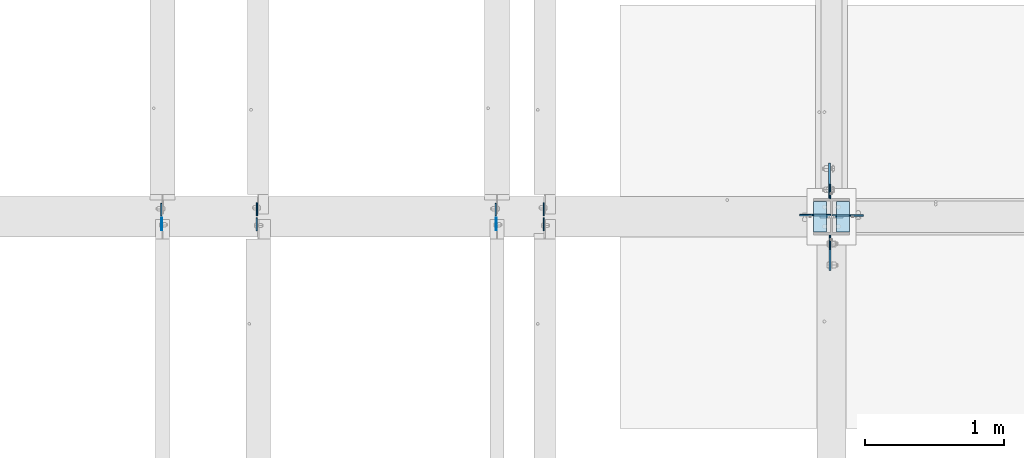
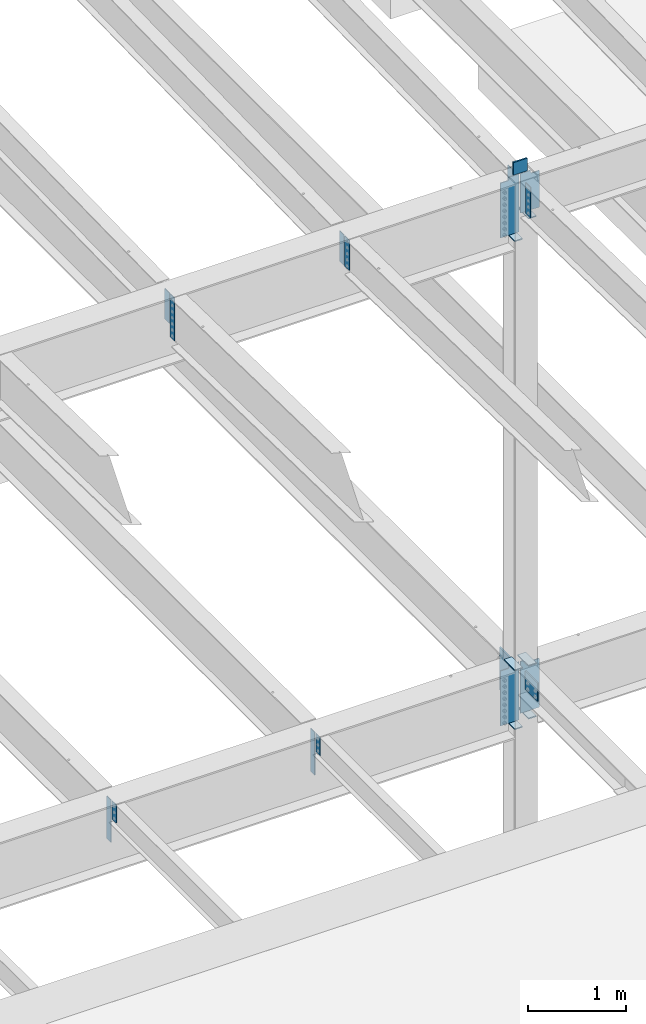
# One storey, part 1558 of 1763: 23 plates, 4 elements without a shape of their own.
"""IFC2X3 building model written with IfcOpenShell, lengths in millimetres."""

from ifc_helpers import new_model, si_unit, frame, origin_with_axes, place, context, subcontext, project, spatial, faceted_brep, material, type_object, element, aggregate, save


model = new_model("IFC2X3")

# Units and contexts
model_context = context("Model", 3, precision=1e-05, world=origin_with_axes())
body_context = subcontext(model_context, "Body", "Model", "MODEL_VIEW")
ifc_project = project(units=[si_unit("LENGTHUNIT", "METRE", prefix="MILLI"), si_unit("AREAUNIT", "SQUARE_METRE"), si_unit("VOLUMEUNIT", "CUBIC_METRE"), si_unit("MASSUNIT", "GRAM", prefix="KILO"), si_unit("TIMEUNIT", "SECOND"), si_unit("PLANEANGLEUNIT", "RADIAN"), si_unit("SOLIDANGLEUNIT", "STERADIAN"), si_unit("THERMODYNAMICTEMPERATUREUNIT", "DEGREE_CELSIUS"), si_unit("LUMINOUSINTENSITYUNIT", "LUMEN")], contexts=[model_context])

# Site, building, storey
site_placement = place(None, origin_with_axes())
site = spatial("IfcSite", under=ifc_project, at=site_placement, CompositionType="ELEMENT")
building_placement = place(site_placement, origin_with_axes())
building = spatial("IfcBuilding", under=site, at=building_placement, Name="Undefined", CompositionType="ELEMENT")
storey_placement = place(building_placement, origin_with_axes())
storey = spatial("IfcBuildingStorey", under=building, at=storey_placement, Name="Undefined", CompositionType="ELEMENT", Elevation=0.0)

# Assembly, plates
assembly_1_placement = place(storey_placement, origin_with_axes())
assembly_1 = element("IfcElementAssembly", 1, at=assembly_1_placement, inside=storey, Name="COLUMN", AssemblyPlace="NOTDEFINED", PredefinedType="RIGID_FRAME")
ifc_material_1 = material(Name="STEEL/A36")
plate_type_1 = type_object("IfcPlateType", PredefinedType="NOTDEFINED")
plate_1_placement = place(assembly_1_placement, frame((-34957.7750236983, 29891.0375000001, 11256.2657630561), z_axis=(0.0, -1.0, 0.0), x_axis=(0.0, 0.0, -1.0)))
plate_1 = element("IfcPlate", 2, at=plate_1_placement, type_object=plate_type_1, material=ifc_material_1, Name="PLATE", context=body_context, shape_type="Brep", body=[
    faceted_brep([(0.0, -3.96900000000096, 0.0), (-1.18234311230481e-11, -3.96900000000096, 101.599998474121), (-1.18234311230481e-11, 3.96900000000096, 101.599998474121), (0.0, 3.96900000000096, 0.0), (381.0, -3.96899999999732, 101.599998474121), (381.0, 3.96899999999732, 101.599998474121), (381.0, -3.96900000001915, 3.34694050252438e-10), (381.0, 3.9690000000046, 3.20142135024071e-10)], [[[0, 1, 2, 3]], [[1, 4, 5, 2]], [[4, 6, 7, 5]], [[6, 0, 3, 7]], [[5, 7, 3, 2]], [[6, 4, 1, 0]]]),
])
plate_2_placement = place(assembly_1_placement, frame((-34957.7750236983, 30154.5624999999, 11256.2236063032), z_axis=(0.0, 1.0, 0.0), x_axis=(0.0, 0.0, -1.0)))
plate_2 = element("IfcPlate", 3, at=plate_2_placement, type_object=plate_type_1, material=ifc_material_1, Name="PLATE", context=body_context, shape_type="Brep", body=[
    faceted_brep([(0.0, -3.96900000000096, 0.0), (-1.18234311230481e-11, -3.96900000000096, 101.599998474121), (-1.18234311230481e-11, 3.96900000000096, 101.599998474121), (0.0, 3.96900000000096, 0.0), (381.0, -3.96899999999732, 101.599998474121), (381.0, 3.96899999999732, 101.599998474121), (381.0, -3.96900000001915, 3.34694050252438e-10), (381.0, 3.9690000000046, 3.20142135024071e-10)], [[[0, 1, 2, 3]], [[1, 4, 5, 2]], [[4, 6, 7, 5]], [[6, 0, 3, 7]], [[5, 7, 3, 2]], [[6, 4, 1, 0]]]),
])

assembly_2_placement = place(storey_placement, origin_with_axes())
assembly_2 = element("IfcElementAssembly", 4, at=assembly_2_placement, inside=storey, Name="BEAM", AssemblyPlace="NOTDEFINED", PredefinedType="RIGID_FRAME")
plate_type_2 = type_object("IfcPlateType", PredefinedType="NOTDEFINED")
plate_3_placement = place(assembly_2_placement, frame((-39776.8956070317, 30029.94375, 5143.5), z_axis=(0.0, 1.0, 0.0), x_axis=(0.0, 0.0, -1.0)))
plate_3 = element("IfcPlate", 5, at=plate_3_placement, type_object=plate_type_2, material=ifc_material_1, Name="PLATE", context=body_context, shape_type="Brep", body=[
    faceted_brep([(0.0, -4.76249999999982, 0.0), (0.0, -4.76250000000073, 88.9000015258789), (0.0, 4.76250000000073, 88.9000015258789), (0.0, 4.76249999999982, 0.0), (533.400024414062, -4.76250000000073, 88.9000015258789), (533.400024414062, 4.76250000000073, 88.9000015258789), (533.400024414062, -4.76250000000073, 0.0), (533.400024414062, 4.76250000000073, 0.0)], [[[0, 1, 2, 3]], [[1, 4, 5, 2]], [[4, 6, 7, 5]], [[6, 0, 3, 7]], [[5, 7, 3, 2]], [[6, 4, 1, 0]]]),
])
plate_4_placement = place(assembly_2_placement, frame((-37368.128940365, 30029.94375, 5143.5), z_axis=(0.0, 1.0, 0.0), x_axis=(0.0, 0.0, -1.0)))
plate_4 = element("IfcPlate", 6, at=plate_4_placement, type_object=plate_type_2, material=ifc_material_1, Name="PLATE", context=body_context, shape_type="Brep", body=[
    faceted_brep([(0.0, -4.76249999999982, 0.0), (0.0, -4.76250000000073, 88.9000015258789), (0.0, 4.76250000000073, 88.9000015258789), (0.0, 4.76249999999982, 0.0), (533.400024414062, -4.76250000000073, 88.9000015258789), (533.400024414062, 4.76250000000073, 88.9000015258789), (533.400024414062, -4.76250000000073, 0.0), (533.400024414062, 4.76250000000073, 0.0)], [[[0, 1, 2, 3]], [[1, 4, 5, 2]], [[4, 6, 7, 5]], [[6, 0, 3, 7]], [[5, 7, 3, 2]], [[6, 4, 1, 0]]]),
])
plate_type_3 = type_object("IfcPlateType", PredefinedType="NOTDEFINED")
plate_5_placement = place(assembly_2_placement, frame((-37364.953940365, 30015.65625, 5143.5), z_axis=(0.0, -1.0, 0.0), x_axis=(0.0, 0.0, -1.0)))
plate_5 = element("IfcPlate", 7, at=plate_5_placement, type_object=plate_type_3, material=ifc_material_1, Name="PLATE", context=body_context, shape_type="Brep", body=[
    faceted_brep([(1.81898940354586e-12, -3.17500000000291, 0.0), (0.0, -3.17499999999927, 88.9000015258789), (0.0, 3.17499999999927, 88.9000015258789), (-1.81898940354586e-12, 3.17499999997381, 0.0), (228.600006103516, -3.17499999999927, 88.9000015258789), (228.600006103516, 3.17499999999927, 88.9000015258789), (228.600006103516, -3.17500000001019, -7.27595761418343e-12), (228.600006103516, 3.17499999999563, -7.27595761418343e-12)], [[[0, 1, 2, 3]], [[1, 4, 5, 2]], [[4, 6, 7, 5]], [[6, 0, 3, 7]], [[5, 7, 3, 2]], [[6, 4, 1, 0]]]),
])
plate_6_placement = place(assembly_2_placement, frame((-39773.7206070317, 30015.65625, 5143.5), z_axis=(0.0, -1.0, 0.0), x_axis=(0.0, 0.0, -1.0)))
plate_6 = element("IfcPlate", 8, at=plate_6_placement, type_object=plate_type_3, material=ifc_material_1, Name="PLATE", context=body_context, shape_type="Brep", body=[
    faceted_brep([(1.81898940354586e-12, -3.17500000000291, 0.0), (0.0, -3.17499999999927, 88.9000015258789), (0.0, 3.17499999999927, 88.9000015258789), (-1.81898940354586e-12, 3.17499999997381, 0.0), (228.600006103516, -3.17499999999927, 88.9000015258789), (228.600006103516, 3.17499999999927, 88.9000015258789), (228.600006103516, -3.17500000001019, -7.27595761418343e-12), (228.600006103516, 3.17499999999563, -7.27595761418343e-12)], [[[0, 1, 2, 3]], [[1, 4, 5, 2]], [[4, 6, 7, 5]], [[6, 0, 3, 7]], [[5, 7, 3, 2]], [[6, 4, 1, 0]]]),
])
aggregate(assembly_2, [plate_3, plate_4, plate_5, plate_6])

# Plate
ifc_material_2 = material(Name="STEEL/A572-50")
plate_type_4 = type_object("IfcPlateType", PredefinedType="NOTDEFINED")
plate_7_placement = place(assembly_1_placement, frame((-34867.2872721725, 30022.8000001452, 11455.3999938869), z_axis=(0.0, 0.0, -1.0), x_axis=(-1.0, 0.0, 0.0)))
plate_7 = element("IfcPlate", 9, at=plate_7_placement, type_object=plate_type_4, material=ifc_material_2, Name="PLATE", context=body_context, shape_type="Brep", body=[
    faceted_brep([(7.27595761418343e-12, 9.52500000000146, 155.574990844727), (-1.45519152283669e-11, 7.27595761418343e-12, 165.099990844727), (165.099990844727, 0.0, 165.099990844727), (165.099990844727, 9.52500000000146, 155.574990844727), (-3.63797880709171e-11, -9.5249999999869, 155.574990844727), (165.099990844727, -9.52500000000146, 155.574990844727), (0.0, 9.52500000000146, 0.0), (0.0, -9.52500000000146, 0.0), (165.099990844727, -9.52500000000146, 0.0), (165.099990844727, 9.52500000000146, 0.0)], [[[0, 1, 2, 3]], [[1, 4, 5, 2]], [[6, 7, 4, 1, 0]], [[5, 8, 9, 3, 2]], [[8, 7, 6, 9]], [[9, 6, 0, 3]], [[7, 8, 5, 4]]]),
])

plate_type_5 = type_object("IfcPlateType", PredefinedType="NOTDEFINED")
plate_8_placement = place(assembly_1_placement, frame((-34821.2497736983, 29911.675, 10775.9500122022), z_axis=(0.0, 1.0, 0.0), x_axis=(-1.0, 0.0, 0.0)))
plate_8 = element("IfcPlate", 10, at=plate_8_placement, type_object=plate_type_5, material=ifc_material_1, Name="PLATE", context=body_context, shape_type="Brep", body=[
    faceted_brep([(0.0, -6.34999999999491, 1.45519152283669e-11), (0.0, -6.35000000000036, 222.25), (0.0, 6.35000000000036, 222.25), (0.0, 6.34999999999491, -2.91038304567337e-11), (93.6624984741211, -6.35000000000036, 222.25), (93.6624984741211, 6.35000000000036, 222.25), (93.6624984741211, -6.35000000000036, 0.0), (93.6624984741211, 6.35000000000036, 0.0)], [[[0, 1, 2, 3]], [[1, 4, 5, 2]], [[4, 6, 7, 5]], [[6, 0, 3, 7]], [[5, 7, 3, 2]], [[6, 4, 1, 0]]]),
])

plate_9_placement = place(assembly_1_placement, frame((-35078.4247736984, 30133.925, 10547.2838431128), z_axis=(0.0, -1.0, 0.0), x_axis=(1.0, 0.0, 0.0)))
plate_9 = element("IfcPlate", 11, at=plate_9_placement, type_object=plate_type_5, material=ifc_material_1, Name="PLATE", context=body_context, shape_type="Brep", body=[
    faceted_brep([(0.0, -6.34999999999491, 1.45519152283669e-11), (0.0, -6.35000000000036, 222.25), (0.0, 6.35000000000036, 222.25), (0.0, 6.34999999999491, -2.91038304567337e-11), (93.6624984741211, -6.35000000000036, 222.25), (93.6624984741211, 6.35000000000036, 222.25), (93.6624984741211, -6.35000000000036, 0.0), (93.6624984741211, 6.35000000000036, 0.0)], [[[0, 1, 2, 3]], [[1, 4, 5, 2]], [[4, 6, 7, 5]], [[6, 0, 3, 7]], [[5, 7, 3, 2]], [[6, 4, 1, 0]]]),
])

plate_10_placement = place(assembly_1_placement, frame((-35078.4247736984, 30133.925, 4451.34997558594), z_axis=(0.0, -1.0, 0.0), x_axis=(1.0, 0.0, 0.0)))
plate_10 = element("IfcPlate", 12, at=plate_10_placement, type_object=plate_type_5, material=ifc_material_1, Name="PLATE", context=body_context, shape_type="Brep", body=[
    faceted_brep([(0.0, -6.34999999999491, 1.45519152283669e-11), (0.0, -6.35000000000036, 222.25), (0.0, 6.35000000000036, 222.25), (0.0, 6.34999999999491, -2.91038304567337e-11), (93.6624984741211, -6.35000000000036, 222.25), (93.6624984741211, 6.35000000000036, 222.25), (93.6624984741211, -6.35000000000036, 0.0), (93.6624984741211, 6.35000000000036, 0.0)], [[[0, 1, 2, 3]], [[1, 4, 5, 2]], [[4, 6, 7, 5]], [[6, 0, 3, 7]], [[5, 7, 3, 2]], [[6, 4, 1, 0]]]),
])

plate_11_placement = place(assembly_1_placement, frame((-35078.4247736984, 30133.925, 5187.95), z_axis=(0.0, -1.0, 0.0), x_axis=(1.0, 0.0, 0.0)))
plate_11 = element("IfcPlate", 13, at=plate_11_placement, type_object=plate_type_5, material=ifc_material_1, Name="PLATE", context=body_context, shape_type="Brep", body=[
    faceted_brep([(0.0, -6.34999999999491, 1.45519152283669e-11), (0.0, -6.35000000000036, 222.25), (0.0, 6.35000000000036, 222.25), (0.0, 6.34999999999491, -2.91038304567337e-11), (93.6624984741211, -6.35000000000036, 222.25), (93.6624984741211, 6.35000000000036, 222.25), (93.6624984741211, -6.35000000000036, 0.0), (93.6624984741211, 6.35000000000036, 0.0)], [[[0, 1, 2, 3]], [[1, 4, 5, 2]], [[4, 6, 7, 5]], [[6, 0, 3, 7]], [[5, 7, 3, 2]], [[6, 4, 1, 0]]]),
])

plate_12_placement = place(assembly_1_placement, frame((-34821.2497736983, 29911.675, 4527.54998779297), z_axis=(0.0, 1.0, 0.0), x_axis=(-1.0, 0.0, 0.0)))
plate_12 = element("IfcPlate", 14, at=plate_12_placement, type_object=plate_type_5, material=ifc_material_1, Name="PLATE", context=body_context, shape_type="Brep", body=[
    faceted_brep([(0.0, -6.34999999999491, 1.45519152283669e-11), (0.0, -6.35000000000036, 222.25), (0.0, 6.35000000000036, 222.25), (0.0, 6.34999999999491, -2.91038304567337e-11), (93.6624984741211, -6.35000000000036, 222.25), (93.6624984741211, 6.35000000000036, 222.25), (93.6624984741211, -6.35000000000036, 0.0), (93.6624984741211, 6.35000000000036, 0.0)], [[[0, 1, 2, 3]], [[1, 4, 5, 2]], [[4, 6, 7, 5]], [[6, 0, 3, 7]], [[5, 7, 3, 2]], [[6, 4, 1, 0]]]),
])

plate_13_placement = place(assembly_1_placement, frame((-34821.2497736983, 29911.675, 5187.95), z_axis=(0.0, 1.0, 0.0), x_axis=(-1.0, 0.0, 0.0)))
plate_13 = element("IfcPlate", 15, at=plate_13_placement, type_object=plate_type_5, material=ifc_material_1, Name="PLATE", context=body_context, shape_type="Brep", body=[
    faceted_brep([(0.0, -6.34999999999491, 1.45519152283669e-11), (0.0, -6.35000000000036, 222.25), (0.0, 6.35000000000036, 222.25), (0.0, 6.34999999999491, -2.91038304567337e-11), (93.6624984741211, -6.35000000000036, 222.25), (93.6624984741211, 6.35000000000036, 222.25), (93.6624984741211, -6.35000000000036, 0.0), (93.6624984741211, 6.35000000000036, 0.0)], [[[0, 1, 2, 3]], [[1, 4, 5, 2]], [[4, 6, 7, 5]], [[6, 0, 3, 7]], [[5, 7, 3, 2]], [[6, 4, 1, 0]]]),
])

# Assembly, plates
assembly_3_placement = place(storey_placement, origin_with_axes())
assembly_3 = element("IfcElementAssembly", 16, at=assembly_3_placement, inside=storey, Name="BEAM", AssemblyPlace="NOTDEFINED", PredefinedType="RIGID_FRAME")
plate_type_6 = type_object("IfcPlateType", PredefinedType="NOTDEFINED")
plate_14_placement = place(assembly_3_placement, frame((-37022.4321665555, 30029.9437498557, 11239.2233504332), z_axis=(0.0, 1.0, 0.0), x_axis=(0.0, 0.0, -1.0)))
plate_14 = element("IfcPlate", 17, at=plate_14_placement, type_object=plate_type_6, material=ifc_material_1, Name="PLATE", context=body_context, shape_type="Brep", body=[
    faceted_brep([(0.0, -3.96900000000096, 0.0), (0.0, -3.96900000000096, 95.25), (0.0, 3.96900000000096, 95.25), (0.0, 3.96900000000096, 0.0), (381.0, -3.96899999999732, 95.25), (381.0, 3.96899999999732, 95.25), (381.0, -3.96900000001915, 3.34694050252438e-10), (381.0, 3.9690000000046, 3.20142135024071e-10)], [[[0, 1, 2, 3]], [[1, 4, 5, 2]], [[4, 6, 7, 5]], [[6, 0, 3, 7]], [[5, 7, 3, 2]], [[6, 4, 1, 0]]]),
])
plate_15_placement = place(assembly_3_placement, frame((-39087.0893094127, 30029.9437498557, 11239.223350434), z_axis=(0.0, 1.0, 0.0), x_axis=(0.0, 0.0, -1.0)))
plate_15 = element("IfcPlate", 18, at=plate_15_placement, type_object=plate_type_6, material=ifc_material_1, Name="PLATE", context=body_context, shape_type="Brep", body=[
    faceted_brep([(0.0, -3.96900000000096, 0.0), (0.0, -3.96900000000096, 95.25), (0.0, 3.96900000000096, 95.25), (0.0, 3.96900000000096, 0.0), (381.0, -3.96899999999732, 95.25), (381.0, 3.96899999999732, 95.25), (381.0, -3.96900000001915, 3.34694050252438e-10), (381.0, 3.9690000000046, 3.20142135024071e-10)], [[[0, 1, 2, 3]], [[1, 4, 5, 2]], [[4, 6, 7, 5]], [[6, 0, 3, 7]], [[5, 7, 3, 2]], [[6, 4, 1, 0]]]),
])

# Plate
plate_type_7 = type_object("IfcPlateType", PredefinedType="NOTDEFINED")
plate_16_placement = place(assembly_1_placement, frame((-34960.9497736983, 29891.0375, 5156.2), z_axis=(0.0, -1.0, 0.0), x_axis=(0.0, 0.0, -1.0)))
plate_16 = element("IfcPlate", 19, at=plate_16_placement, type_object=plate_type_7, material=ifc_material_2, Name="PLATE", context=body_context, shape_type="Brep", body=[
    faceted_brep([(0.0, -6.34999999999491, 1.45519152283669e-11), (0.0, -6.34999999999854, 254.0), (0.0, 6.34999999999854, 254.0), (0.0, 6.34999999999491, -2.91038304567337e-11), (228.600006103516, -6.34999999999854, 254.0), (228.600006103516, 6.34999999999854, 254.0), (228.600006103565, -6.34999999936554, -7.49423634260893e-10), (228.600006103557, 6.35000000064611, -7.13043846189976e-10)], [[[0, 1, 2, 3]], [[1, 4, 5, 2]], [[4, 6, 7, 5]], [[6, 0, 3, 7]], [[5, 7, 3, 2]], [[6, 4, 1, 0]]]),
])

plate_type_8 = type_object("IfcPlateType", PredefinedType="NOTDEFINED")
plate_17_placement = place(assembly_1_placement, frame((-34964.1247736983, 30154.5625, 5143.5), z_axis=(0.0, 1.0, 0.0), x_axis=(0.0, 0.0, -1.0)))
plate_17 = element("IfcPlate", 20, at=plate_17_placement, type_object=plate_type_8, material=ifc_material_2, Name="PLATE", context=body_context, shape_type="Brep", body=[
    faceted_brep([(-7.27595761418343e-12, -7.9375, 0.0), (0.0, -7.9375, 254.0), (0.0, 7.9375, 254.0), (-7.27595761418343e-12, 7.9375, 0.0), (533.400024414062, -7.9375, 254.0), (533.400024414062, 7.9375, 254.0), (533.400024414062, -7.9375, 0.0), (533.400024414062, 7.9375, 0.0)], [[[0, 1, 2, 3]], [[1, 4, 5, 2]], [[4, 6, 7, 5]], [[6, 0, 3, 7]], [[5, 7, 3, 2]], [[6, 4, 1, 0]]]),
])

plate_type_9 = type_object("IfcPlateType", PredefinedType="NOTDEFINED")
plate_18_placement = place(assembly_1_placement, frame((-34943.4872736984, 30033.1187501452, 11277.5999999952), z_axis=(1.0, 0.0, 0.0), x_axis=(0.0, 0.0, -1.0)))
plate_18 = element("IfcPlate", 21, at=plate_18_placement, type_object=plate_type_9, material=ifc_material_1, Name="PLATE", context=body_context, shape_type="Brep", body=[
    faceted_brep([(25.4000001907334, -4.76250000000073, 122.237503051758), (25.4000001907334, 4.76250000000073, 122.237503051758), (-2.5465851649642e-11, 4.76250000019581, 122.237500000236), (-3.45607986673713e-11, -4.76249999983202, 122.23750000025), (30.2600797087798, -4.76250000000073, 123.204232974349), (30.2600797087798, 4.76250000000073, 123.204232974349), (34.3802561769335, -4.76250000000073, 125.957246874823), (34.3802561769335, 4.76250000000073, 125.957246874823), (37.133270077411, -4.76250000000073, 130.077423342977), (37.133270077411, 4.76250000000073, 130.077423342977), (38.0999999999985, -4.76250000000073, 134.937502861023), (38.0999999999985, 4.76250000000073, 134.937502861023), (38.0999999999985, -4.76250000000073, 223.837493896484), (38.0999999999985, 4.76250000000073, 223.837493896484), (495.299987792969, -4.76250000000073, 0.0), (0.0, -4.76249999999982, 0.0), (0.0, 4.76249999999982, 0.0), (495.299987792969, 4.76250000000073, 0.0), (495.299987792969, -4.76250000000073, 223.837493896484), (495.299987792969, 4.76250000000073, 223.837493896484)], [[[0, 1, 2, 3]], [[4, 5, 1, 0]], [[6, 7, 5, 4]], [[8, 9, 7, 6]], [[10, 11, 9, 8]], [[12, 13, 11, 10]], [[14, 15, 16, 17]], [[18, 14, 17, 19]], [[8, 6, 4, 0, 3, 15, 14, 18, 12, 10]], [[16, 15, 3, 2]], [[19, 17, 16, 2, 1, 5, 7, 9, 11, 13]], [[18, 19, 13, 12]]]),
])

plate_19_placement = place(assembly_1_placement, frame((-34956.1872736983, 30034.7062498557, 11277.5338675269), z_axis=(-1.0, 0.0, 0.0), x_axis=(0.0, 0.0, -1.0)))
plate_19 = element("IfcPlate", 22, at=plate_19_placement, type_object=plate_type_9, material=ifc_material_1, Name="PLATE", context=body_context, shape_type="Brep", body=[
    faceted_brep([(25.4000001907334, -4.76250000000073, 122.237503051758), (25.4000001907334, 4.76250000000073, 122.237503051758), (-2.5465851649642e-11, 4.76250000019581, 122.237500000236), (-3.45607986673713e-11, -4.76249999983202, 122.23750000025), (30.2600797087798, -4.76250000000073, 123.204232974349), (30.2600797087798, 4.76250000000073, 123.204232974349), (34.3802561769335, -4.76250000000073, 125.957246874823), (34.3802561769335, 4.76250000000073, 125.957246874823), (37.133270077411, -4.76250000000073, 130.077423342977), (37.133270077411, 4.76250000000073, 130.077423342977), (38.0999999999985, -4.76250000000073, 134.937502861023), (38.0999999999985, 4.76250000000073, 134.937502861023), (38.0999999999985, -4.76250000000073, 223.837493896484), (38.0999999999985, 4.76250000000073, 223.837493896484), (723.900024414062, -4.76250000000073, 0.0), (0.0, -4.76249999999982, 0.0), (0.0, 4.76249999999982, 0.0), (723.900024414062, 4.76250000000073, 0.0), (723.900024414062, -4.76250000000073, 223.837493896484), (723.900024414062, 4.76250000000073, 223.837493896484)], [[[0, 1, 2, 3]], [[4, 5, 1, 0]], [[6, 7, 5, 4]], [[8, 9, 7, 6]], [[10, 11, 9, 8]], [[12, 13, 11, 10]], [[14, 15, 16, 17]], [[18, 14, 17, 19]], [[8, 6, 4, 0, 3, 15, 14, 18, 12, 10]], [[16, 15, 3, 2]], [[19, 17, 16, 2, 1, 5, 7, 9, 11, 13]], [[18, 19, 13, 12]]]),
])

plate_20_placement = place(assembly_1_placement, frame((-34956.1872736983, 30034.70625, 5181.6), z_axis=(-1.0, 0.0, 0.0), x_axis=(0.0, 0.0, -1.0)))
plate_20 = element("IfcPlate", 23, at=plate_20_placement, type_object=plate_type_9, material=ifc_material_1, Name="PLATE", context=body_context, shape_type="Brep", body=[
    faceted_brep([(25.4000001907334, -4.76250000000073, 122.237503051758), (25.4000001907334, 4.76250000000073, 122.237503051758), (-2.5465851649642e-11, 4.76250000019581, 122.237500000236), (-3.45607986673713e-11, -4.76249999983202, 122.23750000025), (30.2600797087798, -4.76250000000073, 123.204232974349), (30.2600797087798, 4.76250000000073, 123.204232974349), (34.3802561769335, -4.76250000000073, 125.957246874823), (34.3802561769335, 4.76250000000073, 125.957246874823), (37.133270077411, -4.76250000000073, 130.077423342977), (37.133270077411, 4.76250000000073, 130.077423342977), (38.0999999999985, -4.76250000000073, 134.937502861023), (38.0999999999985, 4.76250000000073, 134.937502861023), (38.0999999999985, -4.76250000000073, 223.837493896484), (38.0999999999985, 4.76250000000073, 223.837493896484), (723.900024414062, -4.76250000000073, 0.0), (0.0, -4.76249999999982, 0.0), (0.0, 4.76249999999982, 0.0), (723.900024414062, 4.76250000000073, 0.0), (723.900024414062, -4.76250000000073, 223.837493896484), (723.900024414062, 4.76250000000073, 223.837493896484)], [[[0, 1, 2, 3]], [[4, 5, 1, 0]], [[6, 7, 5, 4]], [[8, 9, 7, 6]], [[10, 11, 9, 8]], [[12, 13, 11, 10]], [[14, 15, 16, 17]], [[18, 14, 17, 19]], [[8, 6, 4, 0, 3, 15, 14, 18, 12, 10]], [[16, 15, 3, 2]], [[19, 17, 16, 2, 1, 5, 7, 9, 11, 13]], [[18, 19, 13, 12]]]),
])

plate_21_placement = place(assembly_1_placement, frame((-34943.4872736984, 30033.9125, 5181.6), z_axis=(1.0, 0.0, 0.0), x_axis=(0.0, 0.0, -1.0)))
plate_21 = element("IfcPlate", 24, at=plate_21_placement, type_object=plate_type_9, material=ifc_material_1, Name="PLATE", context=body_context, shape_type="Brep", body=[
    faceted_brep([(25.4000001907334, -4.76250000000073, 122.237503051758), (25.4000001907334, 4.76250000000073, 122.237503051758), (-2.5465851649642e-11, 4.76250000019581, 122.237500000236), (-3.45607986673713e-11, -4.76249999983202, 122.23750000025), (30.2600797087798, -4.76250000000073, 123.204232974349), (30.2600797087798, 4.76250000000073, 123.204232974349), (34.3802561769335, -4.76250000000073, 125.957246874823), (34.3802561769335, 4.76250000000073, 125.957246874823), (37.133270077411, -4.76250000000073, 130.077423342977), (37.133270077411, 4.76250000000073, 130.077423342977), (38.0999999999985, -4.76250000000073, 134.937502861023), (38.0999999999985, 4.76250000000073, 134.937502861023), (38.0999999999985, -4.76250000000073, 223.837493896484), (38.0999999999985, 4.76250000000073, 223.837493896484), (647.700012207031, -4.76250000000073, 0.0), (0.0, -4.76249999999982, 0.0), (0.0, 4.76249999999982, 0.0), (647.700012207031, 4.76250000000073, 0.0), (647.700012207031, -4.76250000000073, 223.837493896484), (647.700012207031, 4.76250000000073, 223.837493896484)], [[[0, 1, 2, 3]], [[4, 5, 1, 0]], [[6, 7, 5, 4]], [[8, 9, 7, 6]], [[10, 11, 9, 8]], [[12, 13, 11, 10]], [[14, 15, 16, 17]], [[18, 14, 17, 19]], [[8, 6, 4, 0, 3, 15, 14, 18, 12, 10]], [[16, 15, 3, 2]], [[19, 17, 16, 2, 1, 5, 7, 9, 11, 13]], [[18, 19, 13, 12]]]),
])

aggregate(assembly_1, [plate_7, plate_8, plate_18, plate_9, plate_19, plate_1, plate_2, plate_10, plate_11, plate_20, plate_12, plate_13, plate_21, plate_16, plate_17])

plate_type_10 = type_object("IfcPlateType", PredefinedType="NOTDEFINED")
plate_22_placement = place(assembly_3_placement, frame((-37022.4321665555, 30015.6562498557, 11239.2036569044), z_axis=(0.0, -1.0, 0.0), x_axis=(0.0, 0.0, -1.0)))
plate_22 = element("IfcPlate", 25, at=plate_22_placement, type_object=plate_type_10, material=ifc_material_1, Name="PLATE", context=body_context, shape_type="Brep", body=[
    faceted_brep([(0.0, -3.96900000000096, 0.0), (0.0, -3.96899999999732, 93.6624984741211), (0.0, 3.96899999999732, 93.6624984741211), (0.0, 3.96900000000096, 0.0), (381.0, -3.96899999999732, 93.6624984741211), (381.0, 3.96899999999732, 93.6624984741211), (381.0, -3.96900000001915, 3.34694050252438e-10), (381.0, 3.9690000000046, 3.20142135024071e-10)], [[[0, 1, 2, 3]], [[1, 4, 5, 2]], [[4, 6, 7, 5]], [[6, 0, 3, 7]], [[5, 7, 3, 2]], [[6, 4, 1, 0]]]),
])

aggregate(assembly_3, [plate_22, plate_14, plate_15])

# Assembly, plate
assembly_4_placement = place(storey_placement, origin_with_axes())
assembly_4 = element("IfcElementAssembly", 26, at=assembly_4_placement, inside=storey, Name="BEAM", AssemblyPlace="NOTDEFINED", PredefinedType="RIGID_FRAME")
plate_type_11 = type_object("IfcPlateType", PredefinedType="NOTDEFINED")
plate_23_placement = place(assembly_4_placement, frame((-39088.6765594127, 30015.6562498557, 11239.2036569036), z_axis=(0.0, -1.0, 0.0), x_axis=(0.0, 0.0, -1.0)))
plate_23 = element("IfcPlate", 27, at=plate_23_placement, type_object=plate_type_11, material=ifc_material_1, Name="PLATE", context=body_context, shape_type="Brep", body=[
    faceted_brep([(0.0, -4.76249999999982, 0.0), (0.0, -4.76249999999709, 93.6624984741211), (0.0, 4.76249999999709, 93.6624984741211), (0.0, 4.76249999999982, 0.0), (533.400024414062, -4.76249999999709, 93.6624984741211), (533.400024414062, 4.76249999999709, 93.6624984741211), (533.400024414062, -4.76250000000073, 0.0), (533.400024414062, 4.76250000000073, 0.0)], [[[0, 1, 2, 3]], [[1, 4, 5, 2]], [[4, 6, 7, 5]], [[6, 0, 3, 7]], [[5, 7, 3, 2]], [[6, 4, 1, 0]]]),
])
aggregate(assembly_4, [plate_23])

save(model, "model.ifc")
